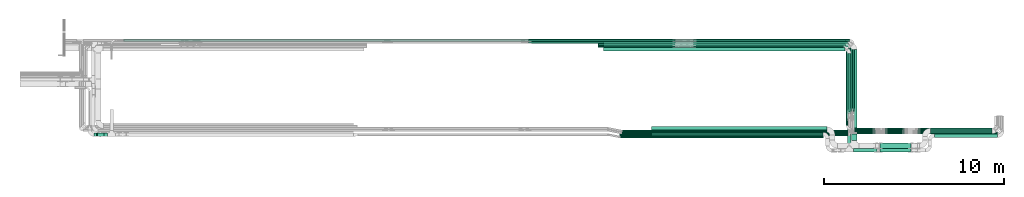
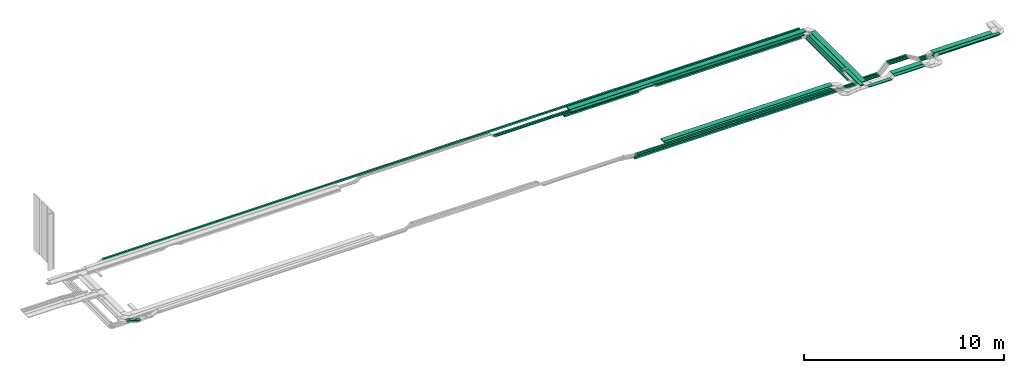
# One storey, part 2 of 19: 41 flow segments.
"""IFC2X3 building model written with IfcOpenShell, lengths in millimetres."""

from ifc_helpers import new_model, entity, si_unit, converted_unit, derived_unit, direction, frame, frame_2d, origin, origin_2d_with_axis, place, context, subcontext, project, spatial, rectangle, extrude, type_object, element, save


model = new_model("IFC2X3")

# Units and contexts
model_context = context("Model", 3, precision=0.01, world=origin(), true_north=direction((6.12303176911189e-17, 1.0)))
body_context = subcontext(model_context, "Body", "Model", "MODEL_VIEW")
ifc_project = project(units=[si_unit("LENGTHUNIT", "METRE", prefix="MILLI"), si_unit("AREAUNIT", "SQUARE_METRE"), si_unit("VOLUMEUNIT", "CUBIC_METRE"), converted_unit("PLANEANGLEUNIT", "DEGREE", entity("IfcRatioMeasure", 0.0174532925199433), si_unit("PLANEANGLEUNIT", "RADIAN"), dimensions=[0, 0, 0, 0, 0, 0, 0]), si_unit("MASSUNIT", "GRAM", prefix="KILO"), derived_unit("MASSDENSITYUNIT", [(si_unit("MASSUNIT", "GRAM", prefix="KILO"), 1), (si_unit("LENGTHUNIT", "METRE"), -3)]), derived_unit("MOMENTOFINERTIAUNIT", [(si_unit("LENGTHUNIT", "METRE"), 4)]), si_unit("TIMEUNIT", "SECOND"), si_unit("FREQUENCYUNIT", "HERTZ"), si_unit("THERMODYNAMICTEMPERATUREUNIT", "DEGREE_CELSIUS"), derived_unit("THERMALTRANSMITTANCEUNIT", [(si_unit("MASSUNIT", "GRAM", prefix="KILO"), 1), (si_unit("THERMODYNAMICTEMPERATUREUNIT", "KELVIN"), -1), (si_unit("TIMEUNIT", "SECOND"), -3)]), derived_unit("VOLUMETRICFLOWRATEUNIT", [(si_unit("LENGTHUNIT", "METRE"), 3), (si_unit("TIMEUNIT", "SECOND"), -1)]), derived_unit("MASSFLOWRATEUNIT", [(si_unit("MASSUNIT", "GRAM", prefix="KILO"), 1), (si_unit("TIMEUNIT", "SECOND"), -1)]), derived_unit("ROTATIONALFREQUENCYUNIT", [(si_unit("TIMEUNIT", "SECOND"), -1)]), si_unit("ELECTRICCURRENTUNIT", "AMPERE"), si_unit("ELECTRICVOLTAGEUNIT", "VOLT"), si_unit("POWERUNIT", "WATT"), si_unit("FORCEUNIT", "NEWTON", prefix="KILO"), si_unit("ILLUMINANCEUNIT", "LUX"), si_unit("LUMINOUSFLUXUNIT", "LUMEN"), si_unit("LUMINOUSINTENSITYUNIT", "CANDELA"), derived_unit("USERDEFINED", [(si_unit("MASSUNIT", "GRAM", prefix="KILO"), -1), (si_unit("LENGTHUNIT", "METRE"), -2), (si_unit("TIMEUNIT", "SECOND"), 3), (si_unit("LUMINOUSFLUXUNIT", "LUMEN"), 1)]), derived_unit("LINEARVELOCITYUNIT", [(si_unit("LENGTHUNIT", "METRE"), 1), (si_unit("TIMEUNIT", "SECOND"), -1)]), si_unit("PRESSUREUNIT", "PASCAL"), derived_unit("USERDEFINED", [(si_unit("LENGTHUNIT", "METRE"), -2), (si_unit("MASSUNIT", "GRAM", prefix="KILO"), 1), (si_unit("TIMEUNIT", "SECOND"), -2)]), derived_unit("LINEARFORCEUNIT", [(si_unit("MASSUNIT", "GRAM", prefix="KILO"), 1), (si_unit("LENGTHUNIT", "METRE"), 1), (si_unit("TIMEUNIT", "SECOND"), -2), (si_unit("LENGTHUNIT", "METRE"), -1)]), derived_unit("PLANARFORCEUNIT", [(si_unit("MASSUNIT", "GRAM", prefix="KILO"), 1), (si_unit("LENGTHUNIT", "METRE"), 1), (si_unit("TIMEUNIT", "SECOND"), -2), (si_unit("LENGTHUNIT", "METRE"), -2)])], contexts=[model_context])

# Site, building, storey
site_placement = place(None, frame((0.0, -0.00077364408347762, 0.0)))
site = spatial("IfcSite", under=ifc_project, at=site_placement, CompositionType="ELEMENT")
building_placement = place(site_placement, origin())
building = spatial("IfcBuilding", under=site, at=building_placement, CompositionType="ELEMENT")
storey_placement = place(building_placement, frame((0.0, 0.0, 12000.0)))
storey = spatial("IfcBuildingStorey", under=building, at=storey_placement, CompositionType="ELEMENT", Elevation=12000.0)

# Flow segments
cable_carrier_segment_type = type_object("IfcCableCarrierSegmentType", PredefinedType="CABLETRAYSEGMENT")
flow_segment_1_placement = place(storey_placement, frame((60092.5531425995, 10765.8096518986, 2800.0)))
element("IfcFlowSegment", 1, at=flow_segment_1_placement, inside=storey, type_object=cable_carrier_segment_type, context=body_context, shape_type="SweptSolid", body=[
    extrude(rectangle(XDim=3330.54307637442, YDim=200.000000000007, at=origin_2d_with_axis()), frame((100.0, 1665.27153818721, 0.0), z_axis=(0.0, 0.0, 1.0), x_axis=(0.0, 1.0, 0.0)), (0.0, 0.0, 1.0), 50.0000000000016),
])
flow_segment_2_placement = place(storey_placement, frame((60312.5531425995, 9254.98776832, 2800.0)))
element("IfcFlowSegment", 2, at=flow_segment_2_placement, inside=storey, type_object=cable_carrier_segment_type, context=body_context, shape_type="SweptSolid", body=[
    extrude(rectangle(XDim=5059.2335274679, YDim=300.000000000001, at=origin_2d_with_axis()), frame((150.0, 2529.61676373395, 0.0), z_axis=(0.0, 0.0, 1.0), x_axis=(0.0, 1.0, 0.0)), (0.0, 0.0, 1.0), 49.9999999999995),
])
flow_segment_3_placement = place(storey_placement, frame((46508.5291362429, 14247.352728273, 2800.0)))
element("IfcFlowSegment", 3, at=flow_segment_3_placement, inside=storey, type_object=cable_carrier_segment_type, context=body_context, shape_type="SweptSolid", body=[
    extrude(rectangle(XDim=13433.0240063567, YDim=200.000000000002, at=frame_2d((0.0, 1.08713038571295e-12), x_axis=(1.0, 0.0))), frame((6716.51200317836, 100.0, 0.0), z_axis=(0.0, 0.0, 1.0), x_axis=(-1.0, 0.0, 0.0)), (0.0, 0.0, 1.0), 50.0000000000016),
])
flow_segment_4_placement = place(storey_placement, frame((60368.3480842056, 10890.3542359349, 2500.0)))
element("IfcFlowSegment", 4, at=flow_segment_4_placement, inside=storey, type_object=cable_carrier_segment_type, context=body_context, shape_type="SweptSolid", body=[
    extrude(rectangle(XDim=3751.14255376512, YDim=99.9999999999946, at=frame_2d((-1.02318153949454e-12, 4.33075797445781e-12), x_axis=(1.0, 0.0))), frame((50.0, 1875.57127688256, 0.0), z_axis=(0.0, 0.0, 1.0), x_axis=(0.0, -1.0, 0.0)), (0.0, 0.0, 1.0), 49.9999999999995),
])
flow_segment_5_placement = place(storey_placement, frame((60250.7778409658, 10890.3542359349, 2500.0)))
element("IfcFlowSegment", 5, at=flow_segment_5_placement, inside=storey, type_object=cable_carrier_segment_type, context=body_context, shape_type="SweptSolid", body=[
    extrude(rectangle(XDim=3632.27563899094, YDim=99.9999999999946, at=frame_2d((1.13686837721616e-12, 0.0), x_axis=(1.0, 0.0))), frame((50.0, 1816.13781949547, 0.0), z_axis=(0.0, 0.0, 1.0), x_axis=(0.0, 1.0, 0.0)), (0.0, 0.0, 1.0), 50.0000000000038),
])
flow_segment_6_placement = place(storey_placement, frame((60138.9654894684, 10847.2909422743, 2500.0)))
element("IfcFlowSegment", 6, at=flow_segment_6_placement, inside=storey, type_object=cable_carrier_segment_type, context=body_context, shape_type="SweptSolid", body=[
    extrude(rectangle(XDim=3567.9496186023, YDim=99.9999999999946, at=frame_2d((1.13686837721616e-12, 8.66506866259442e-12), x_axis=(1.0, 0.0))), frame((50.0, 1783.97480930115, 0.0), z_axis=(0.0, 0.0, 1.0), x_axis=(0.0, 1.0, 0.0)), (0.0, 0.0, 1.0), 99.9999999999989),
])
flow_segment_7_placement = place(storey_placement, frame((46208.5291362429, 14442.4967896999, 2500.0)))
element("IfcFlowSegment", 7, at=flow_segment_7_placement, inside=storey, type_object=cable_carrier_segment_type, context=body_context, shape_type="SweptSolid", body=[
    extrude(rectangle(XDim=4287.07760645673, YDim=99.9999999999989, at=frame_2d((-4.32009983342141e-12, 0.0), x_axis=(1.0, 0.0))), frame((2143.53880322836, 50.0, 0.0), z_axis=(0.0, 0.0, 1.0), x_axis=(-1.0, 0.0, 0.0)), (0.0, 0.0, 1.0), 99.9999999999989),
])
flow_segment_8_placement = place(storey_placement, frame((19798.0584686497, 14792.4967897, 2800.0)))
element("IfcFlowSegment", 8, at=flow_segment_8_placement, inside=storey, type_object=cable_carrier_segment_type, context=body_context, shape_type="SweptSolid", body=[
    extrude(rectangle(XDim=40187.0284882172, YDim=99.9999999999989, at=frame_2d((-5.45696821063757e-12, 0.0), x_axis=(1.0, 0.0))), frame((20093.5142441086, 50.0, 0.0)), (0.0, 0.0, 1.0), 99.9999999999989),
])
flow_segment_9_placement = place(storey_placement, frame((47415.3197270138, 9517.12992335927, 2500.0)))
element("IfcFlowSegment", 9, at=flow_segment_9_placement, inside=storey, type_object=cable_carrier_segment_type, context=body_context, shape_type="SweptSolid", body=[
    extrude(rectangle(XDim=12780.0, YDim=100.000000000001, at=origin_2d_with_axis()), frame((6390.0, 50.0, 0.0), z_axis=(0.0, 0.0, 1.0), x_axis=(-1.0, 0.0, 0.0)), (0.0, 0.0, 1.0), 99.9999999999989),
])
flow_segment_10_placement = place(storey_placement, frame((47436.2947471417, 9407.44715307412, 2800.0)))
element("IfcFlowSegment", 10, at=flow_segment_10_placement, inside=storey, type_object=cable_carrier_segment_type, context=body_context, shape_type="SweptSolid", body=[
    extrude(rectangle(XDim=11318.649842592, YDim=100.000000000001, at=frame_2d((-4.09272615797818e-12, -5.43565192856477e-13), x_axis=(1.0, 0.0))), frame((5659.32492129602, 50.0, 0.0)), (0.0, 0.0, 1.0), 99.9999999999989),
])
flow_segment_11_placement = place(storey_placement, frame((49194.9445897337, 9517.12992335926, 2800.0)))
element("IfcFlowSegment", 11, at=flow_segment_11_placement, inside=storey, type_object=cable_carrier_segment_type, context=body_context, shape_type="SweptSolid", body=[
    extrude(rectangle(XDim=9534.94822520535, YDim=200.0, at=frame_2d((4.09272615797818e-12, 0.0), x_axis=(1.0, 0.0))), frame((4767.47411260268, 100.0, 0.0), z_axis=(0.0, 0.0, 1.0), x_axis=(-1.0, 0.0, 0.0)), (0.0, 0.0, 1.0), 50.0000000000038),
])
flow_segment_12_placement = place(storey_placement, frame((49194.9445897337, 9727.12992335926, 2800.0)))
element("IfcFlowSegment", 12, at=flow_segment_12_placement, inside=storey, type_object=cable_carrier_segment_type, context=body_context, shape_type="SweptSolid", body=[
    extrude(rectangle(XDim=9744.94822520536, YDim=300.000000000001, at=frame_2d((-8.64019966684282e-12, 0.0), x_axis=(1.0, 0.0))), frame((4872.47411260267, 150.0, 0.0), z_axis=(0.0, 0.0, 1.0), x_axis=(-1.0, 0.0, 0.0)), (0.0, 0.0, 1.0), 50.0000000000016),
])
flow_segment_13_placement = place(storey_placement, frame((18293.1704153334, 9487.44715307421, 2637.3085380416)))
element("IfcFlowSegment", 13, at=flow_segment_13_placement, inside=storey, type_object=cable_carrier_segment_type, context=body_context, shape_type="SweptSolid", body=[
    extrude(rectangle(XDim=100.000000000001, YDim=200.0, at=frame_2d((0.0, 1.98951966012828e-12), x_axis=(0.0, 1.0))), frame((19.5365564242406, 100.0, 208.007992916347), z_axis=(0.920504853454354, 0.0, -0.390731128484766), x_axis=(0.0, 1.0, 0.0)), (0.0, 0.0, 1.0), 414.56320839292),
])
flow_segment_14_placement = place(storey_placement, frame((18717.3344029389, 9487.44715307422, 2628.65031167226)))
element("IfcFlowSegment", 14, at=flow_segment_14_placement, inside=storey, type_object=cable_carrier_segment_type, context=body_context, shape_type="SweptSolid", body=[
    extrude(rectangle(XDim=179.180863905857, YDim=200.0, at=frame_2d((-1.08002495835535e-12, 0.0), x_axis=(1.0, 0.0))), frame((89.5904319529296, 100.0, 0.0)), (0.0, 0.0, 1.0), 99.9999999999989),
])
flow_segment_15_placement = place(storey_placement, frame((18152.6734101346, 9487.44715307421, 2800.0)))
element("IfcFlowSegment", 15, at=flow_segment_15_placement, inside=storey, type_object=cable_carrier_segment_type, context=body_context, shape_type="SweptSolid", body=[
    extrude(rectangle(XDim=137.013575831118, YDim=200.0, at=origin_2d_with_axis()), frame((68.506787915559, 100.0, 0.0), z_axis=(0.0, 0.0, 1.0), x_axis=(-1.0, 0.0, 0.0)), (0.0, 0.0, 1.0), 99.9999999999989),
])
flow_segment_16_placement = place(storey_placement, frame((42324.0006413708, 14792.4967897, 2500.0)))
element("IfcFlowSegment", 16, at=flow_segment_16_placement, inside=storey, type_object=cable_carrier_segment_type, context=body_context, shape_type="SweptSolid", body=[
    extrude(rectangle(XDim=8178.82950919114, YDim=99.9999999999989, at=frame_2d((4.32009983342141e-12, 0.0), x_axis=(1.0, 0.0))), frame((4089.41475459558, 50.0, 0.0), z_axis=(0.0, 0.0, 1.0), x_axis=(-1.0, 0.0, 0.0)), (0.0, 0.0, 1.0), 50.0000000000016),
])
flow_segment_17_placement = place(storey_placement, frame((42335.1102146616, 14673.6298749258, 2500.0)))
element("IfcFlowSegment", 17, at=flow_segment_17_placement, inside=storey, type_object=cable_carrier_segment_type, context=body_context, shape_type="SweptSolid", body=[
    extrude(rectangle(XDim=8167.71993590031, YDim=99.9999999999989, at=origin_2d_with_axis()), frame((4083.85996795016, 50.0, 0.0)), (0.0, 0.0, 1.0), 50.0000000000016),
])
flow_segment_18_placement = place(storey_placement, frame((51517.4226666574, 14566.2405608766, 2500.0)))
element("IfcFlowSegment", 18, at=flow_segment_18_placement, inside=storey, type_object=cable_carrier_segment_type, context=body_context, shape_type="SweptSolid", body=[
    extrude(rectangle(XDim=8470.54282281095, YDim=99.9999999999989, at=frame_2d((-4.54747350886464e-12, 2.16715534406831e-12), x_axis=(1.0, 0.0))), frame((4235.27141140547, 50.0, 0.0), z_axis=(0.0, 0.0, 1.0), x_axis=(-1.0, 0.0, 0.0)), (0.0, 0.0, 1.0), 99.9999999999989),
])
flow_segment_19_placement = place(storey_placement, frame((51517.4226666574, 14442.4967897, 2500.0)))
element("IfcFlowSegment", 19, at=flow_segment_19_placement, inside=storey, type_object=cable_carrier_segment_type, context=body_context, shape_type="SweptSolid", body=[
    extrude(rectangle(XDim=8361.57508724892, YDim=99.9999999999989, at=origin_2d_with_axis()), frame((4180.78754362446, 50.0, 0.0), z_axis=(0.0, 0.0, 1.0), x_axis=(-1.0, 0.0, 0.0)), (0.0, 0.0, 1.0), 99.9999999999989),
])
flow_segment_20_placement = place(storey_placement, frame((51516.7268525036, 14792.4967897, 2500.0)))
element("IfcFlowSegment", 20, at=flow_segment_20_placement, inside=storey, type_object=cable_carrier_segment_type, context=body_context, shape_type="SweptSolid", body=[
    extrude(rectangle(XDim=8700.62123170197, YDim=99.9999999999989, at=frame_2d((-4.54747350886464e-12, -2.16715534406831e-12), x_axis=(1.0, 0.0))), frame((4350.31061585099, 50.0, 0.0), z_axis=(0.0, 0.0, 1.0), x_axis=(-1.0, 0.0, 0.0)), (0.0, 0.0, 1.0), 50.0000000000016),
])
flow_segment_21_placement = place(storey_placement, frame((51516.7268525038, 14673.6298749258, 2500.0)))
element("IfcFlowSegment", 21, at=flow_segment_21_placement, inside=storey, type_object=cable_carrier_segment_type, context=body_context, shape_type="SweptSolid", body=[
    extrude(rectangle(XDim=8583.05098846206, YDim=99.9999999999989, at=origin_2d_with_axis()), frame((4291.52549423103, 50.0, 0.0), z_axis=(0.0, 0.0, 1.0), x_axis=(-1.0, 0.0, 0.0)), (0.0, 0.0, 1.0), 50.0000000000016),
])
flow_segment_22_placement = place(storey_placement, frame((46208.5291362429, 14566.2405608766, 2500.0)))
element("IfcFlowSegment", 22, at=flow_segment_22_placement, inside=storey, type_object=cable_carrier_segment_type, context=body_context, shape_type="SweptSolid", body=[
    extrude(rectangle(XDim=4287.07760645671, YDim=99.9999999999989, at=frame_2d((4.32009983342141e-12, 0.0), x_axis=(1.0, 0.0))), frame((2143.53880322836, 50.0, 0.0), z_axis=(0.0, 0.0, 1.0), x_axis=(-1.0, 0.0, 0.0)), (0.0, 0.0, 1.0), 99.9999999999989),
])
flow_segment_23_placement = place(storey_placement, frame((46508.5291362429, 14465.2212957879, 2800.0)))
element("IfcFlowSegment", 23, at=flow_segment_23_placement, inside=storey, type_object=cable_carrier_segment_type, context=body_context, shape_type="SweptSolid", body=[
    extrude(rectangle(XDim=13653.0240063567, YDim=300.000000000001, at=frame_2d((0.0, -1.08002495835535e-12), x_axis=(1.0, 0.0))), frame((6826.51200317836, 150.0, 0.0), z_axis=(0.0, 0.0, 1.0), x_axis=(-1.0, 0.0, 0.0)), (0.0, 0.0, 1.0), 50.0000000000016),
])
flow_segment_24_placement = place(storey_placement, frame((60029.9977539062, 10095.98776832, 2500.0)))
element("IfcFlowSegment", 24, at=flow_segment_24_placement, inside=storey, type_object=cable_carrier_segment_type, context=body_context, shape_type="SweptSolid", body=[
    extrude(rectangle(XDim=4195.50902138004, YDim=99.9999999999946, at=frame_2d((-1.13686837721616e-12, 0.0), x_axis=(1.0, 0.0))), frame((50.0, 2097.75451069002, 0.0), z_axis=(0.0, 0.0, 1.0), x_axis=(0.0, -1.0, 0.0)), (0.0, 0.0, 1.0), 99.9999999999989),
])
flow_segment_25_placement = place(storey_placement, frame((60280.9977539062, 9844.98776831999, 2500.0)))
element("IfcFlowSegment", 25, at=flow_segment_25_placement, inside=storey, type_object=cable_carrier_segment_type, context=body_context, shape_type="SweptSolid", body=[
    extrude(rectangle(XDim=1335.63246763187, YDim=99.9999999999989, at=frame_2d((4.32009983342141e-12, 1.08357767203415e-12), x_axis=(1.0, 0.0))), frame((667.816233815923, 50.0, 0.0)), (0.0, 0.0, 1.0), 99.9999999999989),
])
flow_segment_26_placement = place(storey_placement, frame((60301.7778409658, 9734.98776832001, 2500.0)))
element("IfcFlowSegment", 26, at=flow_segment_26_placement, inside=storey, type_object=cable_carrier_segment_type, context=body_context, shape_type="SweptSolid", body=[
    extrude(rectangle(XDim=1335.56305869098, YDim=99.9999999999989, at=frame_2d((4.37694325228222e-12, 0.0), x_axis=(1.0, 0.0))), frame((667.781529345488, 50.0, 0.0)), (0.0, 0.0, 1.0), 49.9999999999995),
])
flow_segment_27_placement = place(storey_placement, frame((60419.3480842056, 9624.98776832001, 2500.0)))
element("IfcFlowSegment", 27, at=flow_segment_27_placement, inside=storey, type_object=cable_carrier_segment_type, context=body_context, shape_type="SweptSolid", body=[
    extrude(rectangle(XDim=1217.99281545122, YDim=99.9999999999989, at=frame_2d((-4.32009983342141e-12, 0.0), x_axis=(1.0, 0.0))), frame((608.996407725606, 50.0, 0.0)), (0.0, 0.0, 1.0), 50.0000000000038),
])
flow_segment_28_placement = place(storey_placement, frame((60092.5531425995, 8943.81713290522, 2870.0)))
element("IfcFlowSegment", 28, at=flow_segment_28_placement, inside=storey, type_object=cable_carrier_segment_type, context=body_context, shape_type="SweptSolid", body=[
    extrude(rectangle(XDim=1551.11311760389, YDim=200.000000000007, at=frame_2d((-5.6843418860808e-13, 0.0), x_axis=(1.0, 0.0))), frame((100.0, 775.556558801944, 0.0), z_axis=(0.0, 0.0, 1.0), x_axis=(0.0, 1.0, 0.0)), (0.0, 0.0, 1.0), 50.0000000000016),
])
flow_segment_29_placement = place(storey_placement, frame((60422.5531425995, 8613.81713290522, 2870.0)))
element("IfcFlowSegment", 29, at=flow_segment_29_placement, inside=storey, type_object=cable_carrier_segment_type, context=body_context, shape_type="SweptSolid", body=[
    extrude(rectangle(XDim=1304.54319905022, YDim=200.0, at=origin_2d_with_axis()), frame((652.271599525108, 100.0, 0.0)), (0.0, 0.0, 1.0), 50.0000000000016),
])
flow_segment_30_placement = place(storey_placement, frame((62178.3652862744, 9844.98776832002, 3015.0)))
element("IfcFlowSegment", 30, at=flow_segment_30_placement, inside=storey, type_object=cable_carrier_segment_type, context=body_context, shape_type="SweptSolid", body=[
    extrude(rectangle(XDim=1109.47153976734, YDim=99.9999999999989, at=frame_2d((4.32009983342141e-12, 0.0), x_axis=(1.0, 0.0))), frame((554.735769883655, 50.0, 0.0)), (0.0, 0.0, 1.0), 99.9999999999989),
])
flow_segment_31_placement = place(storey_placement, frame((62178.3652862744, 9734.98776832001, 3015.0)))
element("IfcFlowSegment", 31, at=flow_segment_31_placement, inside=storey, type_object=cable_carrier_segment_type, context=body_context, shape_type="SweptSolid", body=[
    extrude(rectangle(XDim=1109.47153976733, YDim=99.9999999999989, at=origin_2d_with_axis()), frame((554.735769883664, 50.0, 0.0)), (0.0, 0.0, 1.0), 50.0000000000038),
])
flow_segment_32_placement = place(storey_placement, frame((62178.3652862744, 9624.98776832, 3015.0)))
element("IfcFlowSegment", 32, at=flow_segment_32_placement, inside=storey, type_object=cable_carrier_segment_type, context=body_context, shape_type="SweptSolid", body=[
    extrude(rectangle(XDim=1109.47153976728, YDim=99.9999999999989, at=frame_2d((4.37694325228222e-12, 1.08357767203415e-12), x_axis=(1.0, 0.0))), frame((554.735769883647, 50.0, 0.0), z_axis=(0.0, 0.0, 1.0), x_axis=(-1.0, 0.0, 0.0)), (0.0, 0.0, 1.0), 49.9999999999995),
])
flow_segment_33_placement = place(storey_placement, frame((61898.1207282678, 8824.98776832001, 3015.0)))
element("IfcFlowSegment", 33, at=flow_segment_33_placement, inside=storey, type_object=cable_carrier_segment_type, context=body_context, shape_type="SweptSolid", body=[
    extrude(rectangle(XDim=1716.47133961725, YDim=299.999999999999, at=frame_2d((-4.32009983342141e-12, 0.0), x_axis=(1.0, 0.0))), frame((858.235669808627, 150.0, 0.0)), (0.0, 0.0, 1.0), 50.0000000000016),
])
flow_segment_34_placement = place(storey_placement, frame((61898.1162259452, 8613.81713290522, 3014.99549767762)))
element("IfcFlowSegment", 34, at=flow_segment_34_placement, inside=storey, type_object=cable_carrier_segment_type, context=body_context, shape_type="SweptSolid", body=[
    extrude(rectangle(XDim=1716.48336829874, YDim=200.0, at=origin_2d_with_axis()), frame((858.241684149385, 100.0, 0.0)), (0.0, 0.0, 1.0), 50.0000000000016),
])
flow_segment_35_placement = place(storey_placement, frame((64013.4139053652, 9844.98776832002, 2600.0)))
element("IfcFlowSegment", 35, at=flow_segment_35_placement, inside=storey, type_object=cable_carrier_segment_type, context=body_context, shape_type="SweptSolid", body=[
    extrude(rectangle(XDim=4223.08121112039, YDim=99.9999999999989, at=origin_2d_with_axis()), frame((2111.5406055602, 50.0, 0.0), z_axis=(0.0, 0.0, 1.0), x_axis=(-1.0, 0.0, 0.0)), (0.0, 0.0, 1.0), 99.9999999999989),
])
flow_segment_36_placement = place(storey_placement, frame((63999.600211958, 9734.98776832002, 2600.0)))
element("IfcFlowSegment", 36, at=flow_segment_36_placement, inside=storey, type_object=cable_carrier_segment_type, context=body_context, shape_type="SweptSolid", body=[
    extrude(rectangle(XDim=4339.65085120224, YDim=99.9999999999989, at=frame_2d((4.32009983342141e-12, 0.0), x_axis=(1.0, 0.0))), frame((2169.82542560112, 50.0, 0.0)), (0.0, 0.0, 1.0), 50.0000000000016),
])
flow_segment_37_placement = place(storey_placement, frame((63999.600211958, 9624.98776831999, 2600.0)))
element("IfcFlowSegment", 37, at=flow_segment_37_placement, inside=storey, type_object=cable_carrier_segment_type, context=body_context, shape_type="SweptSolid", body=[
    extrude(rectangle(XDim=4444.60515848698, YDim=99.9999999999989, at=frame_2d((4.32009983342141e-12, 0.0), x_axis=(1.0, 0.0))), frame((2222.30257924349, 50.0, 0.0)), (0.0, 0.0, 1.0), 50.0000000000016),
])
flow_segment_38_placement = place(storey_placement, frame((64707.4356901398, 9644.98776832002, 2800.0)))
element("IfcFlowSegment", 38, at=flow_segment_38_placement, inside=storey, type_object=cable_carrier_segment_type, context=body_context, shape_type="SweptSolid", body=[
    extrude(rectangle(XDim=3429.05942634583, YDim=300.000000000001, at=frame_2d((4.43378667114303e-12, 1.08002495835535e-12), x_axis=(1.0, 0.0))), frame((1714.52971317292, 150.0, 0.0), z_axis=(0.0, 0.0, 1.0), x_axis=(-1.0, 0.0, 0.0)), (0.0, 0.0, 1.0), 50.0000000000016),
])
flow_segment_39_placement = place(storey_placement, frame((64926.2254658744, 9424.98776831999, 2800.0)))
element("IfcFlowSegment", 39, at=flow_segment_39_placement, inside=storey, type_object=cable_carrier_segment_type, context=body_context, shape_type="SweptSolid", body=[
    extrude(rectangle(XDim=3526.7213158754, YDim=200.0, at=frame_2d((-4.32009983342141e-12, -5.47117906535277e-13), x_axis=(1.0, 0.0))), frame((1763.36065793771, 100.0, 0.0), z_axis=(0.0, 0.0, 1.0), x_axis=(-1.0, 0.0, 0.0)), (0.0, 0.0, 1.0), 50.0000000000016),
])
flow_segment_40_placement = place(storey_placement, frame((47530.9727740341, 9624.98776831999, 2500.0)))
element("IfcFlowSegment", 40, at=flow_segment_40_placement, inside=storey, type_object=cable_carrier_segment_type, context=body_context, shape_type="SweptSolid", body=[
    extrude(rectangle(XDim=12887.3753101715, YDim=99.9999999999989, at=frame_2d((4.09272615797818e-12, -5.40012479177676e-13), x_axis=(1.0, 0.0))), frame((6443.68765508575, 50.0, 0.0), z_axis=(0.0, 0.0, 1.0), x_axis=(-1.0, 0.0, 0.0)), (0.0, 0.0, 1.0), 50.0000000000016),
])
flow_segment_41_placement = place(storey_placement, frame((47545.1464883263, 9734.98776832002, 2500.0)))
element("IfcFlowSegment", 41, at=flow_segment_41_placement, inside=storey, type_object=cable_carrier_segment_type, context=body_context, shape_type="SweptSolid", body=[
    extrude(rectangle(XDim=12755.6313526395, YDim=99.9999999999989, at=origin_2d_with_axis()), frame((6377.81567631976, 50.0, 0.0), z_axis=(0.0, 0.0, 1.0), x_axis=(-1.0, 0.0, 0.0)), (0.0, 0.0, 1.0), 50.0000000000016),
])

save(model, "model.ifc")
